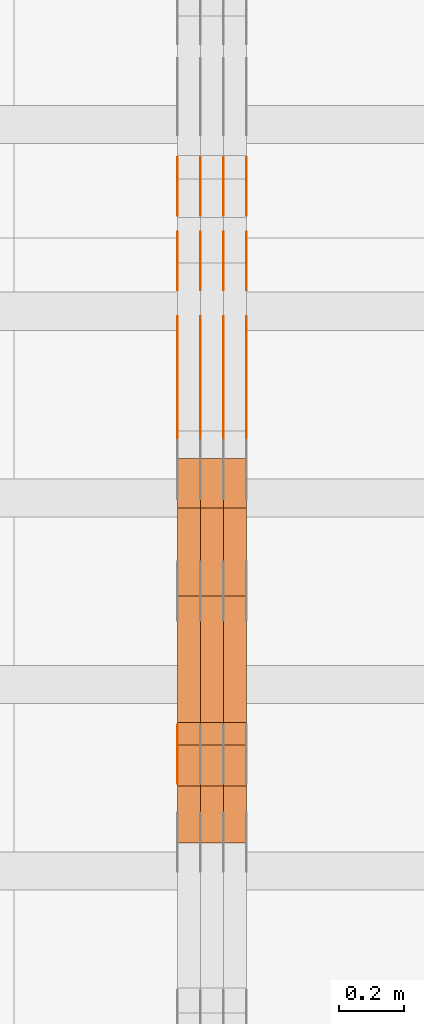
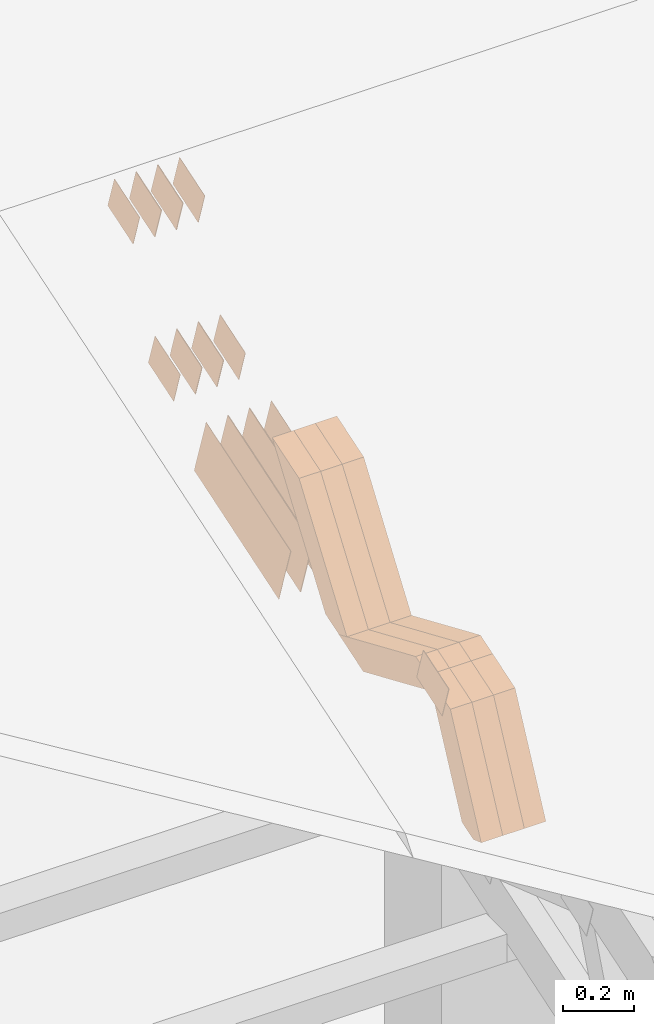
# One storey, part 115 of 385: 28 proxies.
"""IFC2X3 building model written with IfcOpenShell, lengths in millimetres."""

import ifcopenshell
import ifcopenshell.guid

model = None  # the IFC model being written
_history = None  # IfcOwnerHistory: only IFC2X3 demands one
_inside = {}  # id of a spatial element -> (the spatial element, [elements in it])
_under = {}  # id of a project, library or spatial element -> (it, [spatial elements below it])
_declared = {}  # id of a project -> (the project, [libraries it declares])
_typed = {}  # id of a type object -> (the type object, [elements of that type])
_made_of = {}  # id of a material, layer set ... -> (it, [elements and type objects made of it])


def new_model(schema):
    """Start an empty IFC model of exactly this schema.

    Asked for "IFC4X3", IfcOpenShell would pick the latest addendum, in which some entities
    have other attributes; the version numbers below select the first issue.
    IFC2X3 requires an IfcOwnerHistory on every rooted entity: one is made here for all.
    """
    global model, _history
    if schema == "IFC4X3":
        model = ifcopenshell.file(schema_version=(4, 3, 0, 0))
    else:
        model = ifcopenshell.file(schema=schema)
    _inside.clear()
    _under.clear()
    _declared.clear()
    _typed.clear()
    _made_of.clear()
    _history = None
    if model.schema == "IFC2X3":
        org = make("IfcOrganization", Name="unknown")
        user = make(
            "IfcPersonAndOrganization",
            ThePerson=make("IfcPerson", FamilyName="unknown"),
            TheOrganization=org,
        )
        app = make(
            "IfcApplication",
            ApplicationDeveloper=org,
            Version="unknown",
            ApplicationFullName="unknown",
            ApplicationIdentifier="unknown",
        )
        _history = make(
            "IfcOwnerHistory",
            OwningUser=user,
            OwningApplication=app,
            ChangeAction="ADDED",
            CreationDate=0,
        )
    return model


def make(cls, **values):
    """One entity of the class cls with the attributes given. An attribute that is None is left unset."""
    return model.create_entity(
        cls, **{name: value for name, value in values.items() if value is not None}
    )


def entity(cls, *values):
    """Any entity or typed value of the class cls, its attributes in the order of the schema. None: left unset."""
    e = model.create_entity(cls)
    for i, value in enumerate(values):
        if value is not None:
            e[i] = value
    return e


def rooted(cls, **values):
    """An entity with a GlobalId (a new one), such as an element, a storey or a relation."""
    return make(cls, GlobalId=ifcopenshell.guid.new(), OwnerHistory=_history, **values)


def si_unit(unit_type, name, prefix=None):
    """IfcSIUnit, for example si_unit("LENGTHUNIT", "METRE", prefix="MILLI")."""
    return make("IfcSIUnit", UnitType=unit_type, Prefix=prefix, Name=name)


def converted_unit(unit_type, name, factor, base, dimensions=None, offset=None):
    """IfcConversionBasedUnit, such as the inch: factor (a typed value) times the base unit."""
    return make(
        "IfcConversionBasedUnit"
        if offset is None
        else "IfcConversionBasedUnitWithOffset",
        ConversionOffset=offset,
        Dimensions=None
        if dimensions is None
        else entity("IfcDimensionalExponents", *dimensions),
        UnitType=unit_type,
        Name=name,
        ConversionFactor=make(
            "IfcMeasureWithUnit", ValueComponent=factor, UnitComponent=base
        ),
    )


def derived_unit(unit_type, elements):
    """IfcDerivedUnit: a product of units, each with its exponent."""
    return make(
        "IfcDerivedUnit",
        Elements=[
            make("IfcDerivedUnitElement", Unit=unit, Exponent=power)
            for unit, power in elements
        ],
        UnitType=unit_type,
    )


def assignment(units):
    """IfcUnitAssignment: the units of a project."""
    return None if units is None else make("IfcUnitAssignment", Units=units)


def point(xyz):
    """IfcCartesianPoint."""
    return None if xyz is None else make("IfcCartesianPoint", Coordinates=xyz)


def direction(xyz):
    """IfcDirection."""
    return None if xyz is None else make("IfcDirection", DirectionRatios=xyz)


def frame(location, z_axis=None, x_axis=None):
    """IfcAxis2Placement3D, a coordinate frame: its origin and axes. An axis left out is left unset."""
    return make(
        "IfcAxis2Placement3D",
        Location=point(location),
        Axis=direction(z_axis),
        RefDirection=direction(x_axis),
    )


def origin():
    """The frame at (0, 0, 0) with its axes left unset."""
    return frame((0.0, 0.0, 0.0))


def place(relative_to, where):
    """IfcLocalPlacement: puts the frame where relative to a parent placement (None: the world)."""
    return make(
        "IfcLocalPlacement", PlacementRelTo=relative_to, RelativePlacement=where
    )


def context(
    kind, dimensions, precision=None, world=None, true_north=None, identifier=None
):
    """IfcGeometricRepresentationContext, for example the 3D "Model" context."""
    return make(
        "IfcGeometricRepresentationContext",
        ContextIdentifier=identifier,
        ContextType=kind,
        CoordinateSpaceDimension=dimensions,
        Precision=precision,
        WorldCoordinateSystem=world,
        TrueNorth=true_north,
    )


def subcontext(parent, identifier, kind, view, scale=None):
    """IfcGeometricRepresentationSubContext, for example "Body" below "Model"."""
    return make(
        "IfcGeometricRepresentationSubContext",
        ContextIdentifier=identifier,
        ContextType=kind,
        ParentContext=parent,
        TargetScale=scale,
        TargetView=view,
    )


def project(units=None, contexts=None):
    """IfcProject with its units and contexts."""
    return rooted(
        "IfcProject",
        Name="project",
        RepresentationContexts=contexts,
        UnitsInContext=assignment(units),
    )


def spatial(cls, under=None, at=None, **own):
    """A site, building, storey or space (cls), placed at a placement, below another one or the project."""
    s = rooted(cls, ObjectPlacement=at, **own)
    if under is not None:
        _under.setdefault(under.id(), (under, []))[1].append(s)
    return s


def polyline(points):
    """IfcPolyline through the points."""
    return make("IfcPolyline", Points=[point(p) for p in points])


def outline(outer, holes=None, kind="AREA"):
    """IfcArbitraryClosedProfileDef: a profile drawn as a closed curve; with holes, ...WithVoids."""
    if holes is None:
        return make("IfcArbitraryClosedProfileDef", ProfileType=kind, OuterCurve=outer)
    return make(
        "IfcArbitraryProfileDefWithVoids",
        ProfileType=kind,
        OuterCurve=outer,
        InnerCurves=holes,
    )


def extrude(swept, where, along, depth):
    """IfcExtrudedAreaSolid: the profile swept, set in the frame where, extruded along a direction by depth."""
    return make(
        "IfcExtrudedAreaSolid",
        SweptArea=swept,
        Position=where,
        ExtrudedDirection=direction(along),
        Depth=depth,
    )


def shape(context_of_items, identifier, shape_type, items):
    """IfcShapeRepresentation: the items that make up one representation, for example the "Body"."""
    return make(
        "IfcShapeRepresentation",
        ContextOfItems=context_of_items,
        RepresentationIdentifier=identifier,
        RepresentationType=shape_type,
        Items=items,
    )


def source(mapping_origin, context_of_items, identifier, shape_type, items):
    """IfcRepresentationMap: a shape defined once, which mapped items show again and again."""
    return make(
        "IfcRepresentationMap",
        MappingOrigin=mapping_origin,
        MappedRepresentation=shape(context_of_items, identifier, shape_type, items),
    )


def transform(
    local_origin,
    x_axis=None,
    y_axis=None,
    z_axis=None,
    scale=None,
    scale2=None,
    scale3=None,
    uniform=True,
):
    """IfcCartesianTransformationOperator3D, or its non-uniform kind. x_axis, y_axis, z_axis: its Axis1, 2, 3."""
    if uniform:
        return make(
            "IfcCartesianTransformationOperator3D",
            Axis1=direction(x_axis),
            Axis2=direction(y_axis),
            LocalOrigin=point(local_origin),
            Scale=scale,
            Axis3=direction(z_axis),
        )
    return make(
        "IfcCartesianTransformationOperator3DnonUniform",
        Axis1=direction(x_axis),
        Axis2=direction(y_axis),
        LocalOrigin=point(local_origin),
        Scale=scale,
        Axis3=direction(z_axis),
        Scale2=scale2,
        Scale3=scale3,
    )


def mapped(mapping_source, mapping_target):
    """IfcMappedItem: shows the shape of a source again, moved by a transform."""
    return make(
        "IfcMappedItem", MappingSource=mapping_source, MappingTarget=mapping_target
    )


def material(Name=None, Category=None):
    """IfcMaterial."""
    return make("IfcMaterial", Name=Name, Category=Category)


def made_of(thing, what):
    """Note that an element or type object is made of a material, layer set ...; save() writes the relation."""
    if what is not None:
        _made_of.setdefault(what.id(), (what, []))[1].append(thing)
    return thing


def type_object(cls, material=None, **own):
    """A type object (cls), such as IfcWallType, which elements share."""
    return made_of(rooted(cls, **own), material)


def type_shapes(of_type, sources):
    """Give a type object the sources (RepresentationMaps) that its elements show as mapped items."""
    of_type.RepresentationMaps = sources


def element(
    cls,
    number,
    at=None,
    inside=None,
    cuts=None,
    type_object=None,
    material=None,
    context=None,
    identifier="Body",
    shape_type=None,
    held_by="IfcProductDefinitionShape",
    body=None,
    shapes=None,
    **own,
):
    """One element of the class cls, such as IfcWall. Its Tag is "e" and its number.

    at: its placement. inside: the storey or other place that contains it. cuts: it is an
    opening in that element (IfcRelVoidsElement). A single representation is given by context,
    identifier, shape_type and body (its items); several are given by shapes. held_by: the class
    of the entity that holds the representations. save() writes the other relations.
    """
    e = rooted(cls, Tag="e%d" % number, ObjectPlacement=at, **own)
    if body is not None:
        shapes = [shape(context, identifier, shape_type, body)]
    if shapes is not None:
        e.Representation = make(held_by, Representations=shapes)
    if inside is not None:
        _inside.setdefault(inside.id(), (inside, []))[1].append(e)
    if cuts is not None:
        rooted(
            "IfcRelVoidsElement", RelatingBuildingElement=cuts, RelatedOpeningElement=e
        )
    if type_object is not None:
        _typed.setdefault(type_object.id(), (type_object, []))[1].append(e)
    return made_of(e, material)


def aggregate(whole, parts):
    """IfcRelAggregates: a whole, such as a stair, and the parts it consists of."""
    return rooted("IfcRelAggregates", RelatingObject=whole, RelatedObjects=parts)


def save(model, path):
    """Write the relations noted so far, then the file.

    IfcRelAggregates (storeys below a building ...), IfcRelContainedInSpatialStructure (elements
    in a storey), IfcRelDefinesByType, IfcRelAssociatesMaterial and IfcRelDeclares: one each for
    every whole, place, type object, material and project.
    """
    for whole, parts in _under.values():
        aggregate(whole, parts)
    for where, things in _inside.values():
        rooted(
            "IfcRelContainedInSpatialStructure",
            RelatedElements=things,
            RelatingStructure=where,
        )
    for kind, things in _typed.values():
        rooted("IfcRelDefinesByType", RelatedObjects=things, RelatingType=kind)
    for what, things in _made_of.values():
        rooted("IfcRelAssociatesMaterial", RelatedObjects=things, RelatingMaterial=what)
    for by, libraries in _declared.values():
        rooted("IfcRelDeclares", RelatingContext=by, RelatedDefinitions=libraries)
    model.write(path)


model = new_model("IFC2X3")

# Units and contexts
model_context = context("Model", 3, precision=0.01, world=origin(), true_north=direction((6.12303176911189e-17, 1.0)))
body_context = subcontext(model_context, "Body", "Model", "MODEL_VIEW")
ifc_project = project(units=[si_unit("LENGTHUNIT", "METRE", prefix="MILLI"), si_unit("AREAUNIT", "SQUARE_METRE"), si_unit("VOLUMEUNIT", "CUBIC_METRE"), converted_unit("PLANEANGLEUNIT", "DEGREE", entity("IfcRatioMeasure", 0.0174532925199433), si_unit("PLANEANGLEUNIT", "RADIAN"), dimensions=[0, 0, 0, 0, 0, 0, 0]), si_unit("MASSUNIT", "GRAM", prefix="KILO"), derived_unit("MASSDENSITYUNIT", [(si_unit("MASSUNIT", "GRAM", prefix="KILO"), 1), (si_unit("LENGTHUNIT", "METRE"), -3)]), si_unit("TIMEUNIT", "SECOND"), si_unit("FREQUENCYUNIT", "HERTZ"), si_unit("THERMODYNAMICTEMPERATUREUNIT", "DEGREE_CELSIUS"), derived_unit("THERMALTRANSMITTANCEUNIT", [(si_unit("MASSUNIT", "GRAM", prefix="KILO"), 1), (si_unit("THERMODYNAMICTEMPERATUREUNIT", "KELVIN"), -1), (si_unit("TIMEUNIT", "SECOND"), -3)]), derived_unit("VOLUMETRICFLOWRATEUNIT", [(si_unit("LENGTHUNIT", "METRE"), 3), (si_unit("TIMEUNIT", "SECOND"), -1)]), si_unit("ELECTRICCURRENTUNIT", "AMPERE"), si_unit("ELECTRICVOLTAGEUNIT", "VOLT"), si_unit("POWERUNIT", "WATT"), si_unit("FORCEUNIT", "NEWTON", prefix="KILO"), si_unit("ILLUMINANCEUNIT", "LUX"), si_unit("LUMINOUSFLUXUNIT", "LUMEN"), si_unit("LUMINOUSINTENSITYUNIT", "CANDELA"), derived_unit("USERDEFINED", [(si_unit("MASSUNIT", "GRAM", prefix="KILO"), -1), (si_unit("LENGTHUNIT", "METRE"), -2), (si_unit("TIMEUNIT", "SECOND"), 3), (si_unit("LUMINOUSFLUXUNIT", "LUMEN"), 1)]), derived_unit("LINEARVELOCITYUNIT", [(si_unit("LENGTHUNIT", "METRE"), 1), (si_unit("TIMEUNIT", "SECOND"), -1)]), si_unit("PRESSUREUNIT", "PASCAL"), derived_unit("USERDEFINED", [(si_unit("LENGTHUNIT", "METRE"), -2), (si_unit("MASSUNIT", "GRAM", prefix="KILO"), 1), (si_unit("TIMEUNIT", "SECOND"), -2)])], contexts=[model_context])

# Site, building, storey
site_placement = place(None, origin())
site = spatial("IfcSite", under=ifc_project, at=site_placement, CompositionType="ELEMENT")
building_placement = place(site_placement, origin())
building = spatial("IfcBuilding", under=site, at=building_placement, CompositionType="ELEMENT")
storey_placement = place(building_placement, origin())
storey = spatial("IfcBuildingStorey", under=building, at=storey_placement, Name="Default", CompositionType="ELEMENT", Elevation=0.0)

# Proxies
ifc_material_1 = material(Name="IfcSurfaceStyle #247334")
building_element_proxy_type_1 = type_object("IfcBuildingElementProxyType", PredefinedType="NOTDEFINED", material=ifc_material_1)
shared_shape_1 = source(origin(), body_context, "Body", "SweptSolid", [
    extrude(outline(polyline([(-74.9998565677179, -60.000059685226), (74.9998794200128, -60.000059685226), (74.9998565677179, 60.000059685226), (-74.9998794200128, 60.000059685226), (-74.9998565677179, -60.000059685226)])), frame((75.0001976720505, 60.000059685226, 0.0), z_axis=(0.0, 0.0, 1.0), x_axis=(-1.0, 0.0, 0.0)), (0.0, 0.0, 1.0), 1.3),
])
type_shapes(building_element_proxy_type_1, [shared_shape_1])
proxy_1_placement = place(building_placement, frame((18386.3, 8537.53090236182, 1950.11166041942), z_axis=(-1.0, 0.0, 0.0), x_axis=(0.0, 0.951056516295124, 0.309016994375039)))
element("IfcBuildingElementProxy", 1, at=proxy_1_placement, inside=storey, type_object=building_element_proxy_type_1, material=ifc_material_1, context=body_context, shape_type="MappedRepresentation", body=[
    mapped(shared_shape_1, transform((0.0, 0.0, 0.0), scale=1.0)),
])
ifc_material_2 = material(Name="IfcSurfaceStyle #247277")
building_element_proxy_type_2 = type_object("IfcBuildingElementProxyType", PredefinedType="NOTDEFINED", material=ifc_material_2)
shared_shape_2 = source(origin(), body_context, "Body", "SweptSolid", [
    extrude(outline(polyline([(-74.9998565677179, -60.000059685226), (74.9998794200128, -60.000059685226), (74.9998565677179, 60.000059685226), (-74.9998794200128, 60.000059685226), (-74.9998565677179, -60.000059685226)])), frame((75.0001976720505, 60.000059685226, 0.0), z_axis=(0.0, 0.0, 1.0), x_axis=(-1.0, 0.0, 0.0)), (0.0, 0.0, 1.0), 1.3),
])
type_shapes(building_element_proxy_type_2, [shared_shape_2])
proxy_2_placement = place(building_placement, frame((18315.0, 8537.53090236182, 1950.11166041942), z_axis=(-1.0, 0.0, 0.0), x_axis=(0.0, 0.951056516295124, 0.309016994375039)))
element("IfcBuildingElementProxy", 2, at=proxy_2_placement, inside=storey, type_object=building_element_proxy_type_2, material=ifc_material_2, context=body_context, shape_type="MappedRepresentation", body=[
    mapped(shared_shape_2, transform((0.0, 0.0, 0.0), scale=1.0)),
])
ifc_material_3 = material(Name="IfcSurfaceStyle #247220")
building_element_proxy_type_3 = type_object("IfcBuildingElementProxyType", PredefinedType="NOTDEFINED", material=ifc_material_3)
shared_shape_3 = source(origin(), body_context, "Body", "SweptSolid", [
    extrude(outline(polyline([(-74.9998565677179, -60.000059685226), (74.9998794200128, -60.000059685226), (74.9998565677179, 60.000059685226), (-74.9998794200128, 60.000059685226), (-74.9998565677179, -60.000059685226)])), frame((75.0001976720505, 60.000059685226, 0.0), z_axis=(0.0, 0.0, 1.0), x_axis=(-1.0, 0.0, 0.0)), (0.0, 0.0, 1.0), 1.3),
])
type_shapes(building_element_proxy_type_3, [shared_shape_3])
proxy_3_placement = place(building_placement, frame((18316.3, 8537.53090236182, 1950.11166041942), z_axis=(-1.0, 0.0, 0.0), x_axis=(0.0, 0.951056516295124, 0.309016994375039)))
element("IfcBuildingElementProxy", 3, at=proxy_3_placement, inside=storey, type_object=building_element_proxy_type_3, material=ifc_material_3, context=body_context, shape_type="MappedRepresentation", body=[
    mapped(shared_shape_3, transform((0.0, 0.0, 0.0), scale=1.0)),
])
ifc_material_4 = material(Name="IfcSurfaceStyle #247163")
building_element_proxy_type_4 = type_object("IfcBuildingElementProxyType", PredefinedType="NOTDEFINED", material=ifc_material_4)
shared_shape_4 = source(origin(), body_context, "Body", "SweptSolid", [
    extrude(outline(polyline([(-74.9998565677179, -60.000059685226), (74.9998794200128, -60.000059685226), (74.9998565677179, 60.000059685226), (-74.9998794200128, 60.000059685226), (-74.9998565677179, -60.000059685226)])), frame((75.0001976720505, 60.000059685226, 0.0), z_axis=(0.0, 0.0, 1.0), x_axis=(-1.0, 0.0, 0.0)), (0.0, 0.0, 1.0), 1.29999999999999),
])
type_shapes(building_element_proxy_type_4, [shared_shape_4])
proxy_4_placement = place(building_placement, frame((18245.0, 8537.53090236182, 1950.11166041942), z_axis=(-1.0, 0.0, 0.0), x_axis=(0.0, 0.951056516295124, 0.309016994375039)))
element("IfcBuildingElementProxy", 4, at=proxy_4_placement, inside=storey, type_object=building_element_proxy_type_4, material=ifc_material_4, context=body_context, shape_type="MappedRepresentation", body=[
    mapped(shared_shape_4, transform((0.0, 0.0, 0.0), scale=1.0)),
])
ifc_material_5 = material(Name="IfcSurfaceStyle #247106")
building_element_proxy_type_5 = type_object("IfcBuildingElementProxyType", PredefinedType="NOTDEFINED", material=ifc_material_5)
shared_shape_5 = source(origin(), body_context, "Body", "SweptSolid", [
    extrude(outline(polyline([(-74.9998565677179, -60.000059685226), (74.9998794200128, -60.000059685226), (74.9998565677179, 60.000059685226), (-74.9998794200128, 60.000059685226), (-74.9998565677179, -60.000059685226)])), frame((75.0001976720505, 60.000059685226, 0.0), z_axis=(0.0, 0.0, 1.0), x_axis=(-1.0, 0.0, 0.0)), (0.0, 0.0, 1.0), 1.29999999999999),
])
type_shapes(building_element_proxy_type_5, [shared_shape_5])
proxy_5_placement = place(building_placement, frame((18246.3, 8537.53090236182, 1950.11166041942), z_axis=(-1.0, 0.0, 0.0), x_axis=(0.0, 0.951056516295124, 0.309016994375039)))
element("IfcBuildingElementProxy", 5, at=proxy_5_placement, inside=storey, type_object=building_element_proxy_type_5, material=ifc_material_5, context=body_context, shape_type="MappedRepresentation", body=[
    mapped(shared_shape_5, transform((0.0, 0.0, 0.0), scale=1.0)),
])
ifc_material_6 = material(Name="IfcSurfaceStyle #247049")
building_element_proxy_type_6 = type_object("IfcBuildingElementProxyType", PredefinedType="NOTDEFINED", material=ifc_material_6)
shared_shape_6 = source(origin(), body_context, "Body", "SweptSolid", [
    extrude(outline(polyline([(-74.9998565677179, -60.000059685226), (74.9998794200128, -60.000059685226), (74.9998565677179, 60.000059685226), (-74.9998794200128, 60.000059685226), (-74.9998565677179, -60.000059685226)])), frame((75.0001976720505, 60.000059685226, 0.0), z_axis=(0.0, 0.0, 1.0), x_axis=(-1.0, 0.0, 0.0)), (0.0, 0.0, 1.0), 1.29999999999999),
])
type_shapes(building_element_proxy_type_6, [shared_shape_6])
proxy_6_placement = place(building_placement, frame((18175.0, 8537.53090236182, 1950.11166041942), z_axis=(-1.0, 0.0, 0.0), x_axis=(0.0, 0.951056516295124, 0.309016994375039)))
element("IfcBuildingElementProxy", 6, at=proxy_6_placement, inside=storey, type_object=building_element_proxy_type_6, material=ifc_material_6, context=body_context, shape_type="MappedRepresentation", body=[
    mapped(shared_shape_6, transform((0.0, 0.0, 0.0), scale=1.0)),
])
ifc_material_7 = material(Name="IfcSurfaceStyle #246992")
building_element_proxy_type_7 = type_object("IfcBuildingElementProxyType", PredefinedType="NOTDEFINED", material=ifc_material_7)
shared_shape_7 = source(origin(), body_context, "Body", "SweptSolid", [
    extrude(outline(polyline([(-74.9998754286225, -60.0000016373515), (74.9998605591045, -60.0000016373515), (74.9998754286225, 60.0000016373515), (-74.9998605591045, 60.0000016373515), (-74.9998754286225, -60.0000016373515)])), frame((74.9998754286225, 60.0000016373515, 0.0), z_axis=(0.0, 0.0, 1.0), x_axis=(-1.0, 0.0, 0.0)), (0.0, 0.0, 1.0), 1.3),
])
type_shapes(building_element_proxy_type_7, [shared_shape_7])
proxy_7_placement = place(building_placement, frame((18386.3, 8765.47458614632, 2350.86432930304), z_axis=(-1.0, 0.0, 0.0), x_axis=(0.0, 0.951056516295154, 0.309016994374948)))
element("IfcBuildingElementProxy", 7, at=proxy_7_placement, inside=storey, type_object=building_element_proxy_type_7, material=ifc_material_7, context=body_context, shape_type="MappedRepresentation", body=[
    mapped(shared_shape_7, transform((0.0, 0.0, 0.0), scale=1.0)),
])
ifc_material_8 = material(Name="IfcSurfaceStyle #246935")
building_element_proxy_type_8 = type_object("IfcBuildingElementProxyType", PredefinedType="NOTDEFINED", material=ifc_material_8)
shared_shape_8 = source(origin(), body_context, "Body", "SweptSolid", [
    extrude(outline(polyline([(-74.9998754286225, -60.0000016373515), (74.9998605591045, -60.0000016373515), (74.9998754286225, 60.0000016373515), (-74.9998605591045, 60.0000016373515), (-74.9998754286225, -60.0000016373515)])), frame((74.9998754286225, 60.0000016373515, 0.0), z_axis=(0.0, 0.0, 1.0), x_axis=(-1.0, 0.0, 0.0)), (0.0, 0.0, 1.0), 1.3),
])
type_shapes(building_element_proxy_type_8, [shared_shape_8])
proxy_8_placement = place(building_placement, frame((18315.0, 8765.47458614632, 2350.86432930304), z_axis=(-1.0, 0.0, 0.0), x_axis=(0.0, 0.951056516295154, 0.309016994374948)))
element("IfcBuildingElementProxy", 8, at=proxy_8_placement, inside=storey, type_object=building_element_proxy_type_8, material=ifc_material_8, context=body_context, shape_type="MappedRepresentation", body=[
    mapped(shared_shape_8, transform((0.0, 0.0, 0.0), scale=1.0)),
])
ifc_material_9 = material(Name="IfcSurfaceStyle #246878")
building_element_proxy_type_9 = type_object("IfcBuildingElementProxyType", PredefinedType="NOTDEFINED", material=ifc_material_9)
shared_shape_9 = source(origin(), body_context, "Body", "SweptSolid", [
    extrude(outline(polyline([(-74.9998754286225, -60.0000016373515), (74.9998605591045, -60.0000016373515), (74.9998754286225, 60.0000016373515), (-74.9998605591045, 60.0000016373515), (-74.9998754286225, -60.0000016373515)])), frame((74.9998754286225, 60.0000016373515, 0.0), z_axis=(0.0, 0.0, 1.0), x_axis=(-1.0, 0.0, 0.0)), (0.0, 0.0, 1.0), 1.3),
])
type_shapes(building_element_proxy_type_9, [shared_shape_9])
proxy_9_placement = place(building_placement, frame((18316.3, 8765.47458614632, 2350.86432930304), z_axis=(-1.0, 0.0, 0.0), x_axis=(0.0, 0.951056516295154, 0.309016994374948)))
element("IfcBuildingElementProxy", 9, at=proxy_9_placement, inside=storey, type_object=building_element_proxy_type_9, material=ifc_material_9, context=body_context, shape_type="MappedRepresentation", body=[
    mapped(shared_shape_9, transform((0.0, 0.0, 0.0), scale=1.0)),
])
ifc_material_10 = material(Name="IfcSurfaceStyle #246821")
building_element_proxy_type_10 = type_object("IfcBuildingElementProxyType", PredefinedType="NOTDEFINED", material=ifc_material_10)
shared_shape_10 = source(origin(), body_context, "Body", "SweptSolid", [
    extrude(outline(polyline([(-74.9998754286225, -60.0000016373515), (74.9998605591045, -60.0000016373515), (74.9998754286225, 60.0000016373515), (-74.9998605591045, 60.0000016373515), (-74.9998754286225, -60.0000016373515)])), frame((74.9998754286225, 60.0000016373515, 0.0), z_axis=(0.0, 0.0, 1.0), x_axis=(-1.0, 0.0, 0.0)), (0.0, 0.0, 1.0), 1.29999999999999),
])
type_shapes(building_element_proxy_type_10, [shared_shape_10])
proxy_10_placement = place(building_placement, frame((18245.0, 8765.47458614632, 2350.86432930304), z_axis=(-1.0, 0.0, 0.0), x_axis=(0.0, 0.951056516295154, 0.309016994374948)))
element("IfcBuildingElementProxy", 10, at=proxy_10_placement, inside=storey, type_object=building_element_proxy_type_10, material=ifc_material_10, context=body_context, shape_type="MappedRepresentation", body=[
    mapped(shared_shape_10, transform((0.0, 0.0, 0.0), scale=1.0)),
])
ifc_material_11 = material(Name="IfcSurfaceStyle #246764")
building_element_proxy_type_11 = type_object("IfcBuildingElementProxyType", PredefinedType="NOTDEFINED", material=ifc_material_11)
shared_shape_11 = source(origin(), body_context, "Body", "SweptSolid", [
    extrude(outline(polyline([(-74.9998754286225, -60.0000016373515), (74.9998605591045, -60.0000016373515), (74.9998754286225, 60.0000016373515), (-74.9998605591045, 60.0000016373515), (-74.9998754286225, -60.0000016373515)])), frame((74.9998754286225, 60.0000016373515, 0.0), z_axis=(0.0, 0.0, 1.0), x_axis=(-1.0, 0.0, 0.0)), (0.0, 0.0, 1.0), 1.29999999999999),
])
type_shapes(building_element_proxy_type_11, [shared_shape_11])
proxy_11_placement = place(building_placement, frame((18246.3, 8765.47458614632, 2350.86432930304), z_axis=(-1.0, 0.0, 0.0), x_axis=(0.0, 0.951056516295154, 0.309016994374948)))
element("IfcBuildingElementProxy", 11, at=proxy_11_placement, inside=storey, type_object=building_element_proxy_type_11, material=ifc_material_11, context=body_context, shape_type="MappedRepresentation", body=[
    mapped(shared_shape_11, transform((0.0, 0.0, 0.0), scale=1.0)),
])
ifc_material_12 = material(Name="IfcSurfaceStyle #246707")
building_element_proxy_type_12 = type_object("IfcBuildingElementProxyType", PredefinedType="NOTDEFINED", material=ifc_material_12)
shared_shape_12 = source(origin(), body_context, "Body", "SweptSolid", [
    extrude(outline(polyline([(-74.9998754286225, -60.0000016373515), (74.9998605591045, -60.0000016373515), (74.9998754286225, 60.0000016373515), (-74.9998605591045, 60.0000016373515), (-74.9998754286225, -60.0000016373515)])), frame((74.9998754286225, 60.0000016373515, 0.0), z_axis=(0.0, 0.0, 1.0), x_axis=(-1.0, 0.0, 0.0)), (0.0, 0.0, 1.0), 1.29999999999999),
])
type_shapes(building_element_proxy_type_12, [shared_shape_12])
proxy_12_placement = place(building_placement, frame((18175.0, 8765.47458614632, 2350.86432930304), z_axis=(-1.0, 0.0, 0.0), x_axis=(0.0, 0.951056516295154, 0.309016994374948)))
element("IfcBuildingElementProxy", 12, at=proxy_12_placement, inside=storey, type_object=building_element_proxy_type_12, material=ifc_material_12, context=body_context, shape_type="MappedRepresentation", body=[
    mapped(shared_shape_12, transform((0.0, 0.0, 0.0), scale=1.0)),
])
ifc_material_13 = material(Name="IfcSurfaceStyle #246308")
building_element_proxy_type_13 = type_object("IfcBuildingElementProxyType", PredefinedType="NOTDEFINED", material=ifc_material_13)
shared_shape_13 = source(origin(), body_context, "Body", "SweptSolid", [
    extrude(outline(polyline([(-249.999749056184, -108.000229288163), (249.999396050782, -108.000229288163), (249.999749056184, 108.000229288163), (-249.999396050782, 108.000229288163), (-249.999749056184, -108.000229288163)])), frame((249.999841104007, 108.000229288163, 0.0), z_axis=(0.0, 0.0, 1.0), x_axis=(-1.0, 0.0, 0.0)), (0.0, 0.0, 1.0), 1.29999999999998),
])
type_shapes(building_element_proxy_type_13, [shared_shape_13])
proxy_13_placement = place(building_placement, frame((18386.3, 7917.13457673635, 1720.66532252899), z_axis=(-1.0, 0.0, 0.0), x_axis=(0.0, 0.951056516295124, 0.309016994375039)))
element("IfcBuildingElementProxy", 13, at=proxy_13_placement, inside=storey, type_object=building_element_proxy_type_13, material=ifc_material_13, context=body_context, shape_type="MappedRepresentation", body=[
    mapped(shared_shape_13, transform((0.0, 0.0, 0.0), scale=1.0)),
])
ifc_material_14 = material(Name="IfcSurfaceStyle #246251")
building_element_proxy_type_14 = type_object("IfcBuildingElementProxyType", PredefinedType="NOTDEFINED", material=ifc_material_14)
shared_shape_14 = source(origin(), body_context, "Body", "SweptSolid", [
    extrude(outline(polyline([(-249.999749056184, -108.000229288163), (249.999396050782, -108.000229288163), (249.999749056184, 108.000229288163), (-249.999396050782, 108.000229288163), (-249.999749056184, -108.000229288163)])), frame((249.999841104007, 108.000229288163, 0.0), z_axis=(0.0, 0.0, 1.0), x_axis=(-1.0, 0.0, 0.0)), (0.0, 0.0, 1.0), 1.29999999999998),
])
type_shapes(building_element_proxy_type_14, [shared_shape_14])
proxy_14_placement = place(building_placement, frame((18315.0, 7917.13457673635, 1720.66532252899), z_axis=(-1.0, 0.0, 0.0), x_axis=(0.0, 0.951056516295124, 0.309016994375039)))
element("IfcBuildingElementProxy", 14, at=proxy_14_placement, inside=storey, type_object=building_element_proxy_type_14, material=ifc_material_14, context=body_context, shape_type="MappedRepresentation", body=[
    mapped(shared_shape_14, transform((0.0, 0.0, 0.0), scale=1.0)),
])
ifc_material_15 = material(Name="IfcSurfaceStyle #246194")
building_element_proxy_type_15 = type_object("IfcBuildingElementProxyType", PredefinedType="NOTDEFINED", material=ifc_material_15)
shared_shape_15 = source(origin(), body_context, "Body", "SweptSolid", [
    extrude(outline(polyline([(-249.999749056184, -108.000229288163), (249.999396050782, -108.000229288163), (249.999749056184, 108.000229288163), (-249.999396050782, 108.000229288163), (-249.999749056184, -108.000229288163)])), frame((249.999841104007, 108.000229288163, 0.0), z_axis=(0.0, 0.0, 1.0), x_axis=(-1.0, 0.0, 0.0)), (0.0, 0.0, 1.0), 1.29999999999998),
])
type_shapes(building_element_proxy_type_15, [shared_shape_15])
proxy_15_placement = place(building_placement, frame((18316.3, 7917.13457673635, 1720.66532252899), z_axis=(-1.0, 0.0, 0.0), x_axis=(0.0, 0.951056516295124, 0.309016994375039)))
element("IfcBuildingElementProxy", 15, at=proxy_15_placement, inside=storey, type_object=building_element_proxy_type_15, material=ifc_material_15, context=body_context, shape_type="MappedRepresentation", body=[
    mapped(shared_shape_15, transform((0.0, 0.0, 0.0), scale=1.0)),
])
ifc_material_16 = material(Name="IfcSurfaceStyle #246137")
building_element_proxy_type_16 = type_object("IfcBuildingElementProxyType", PredefinedType="NOTDEFINED", material=ifc_material_16)
shared_shape_16 = source(origin(), body_context, "Body", "SweptSolid", [
    extrude(outline(polyline([(-249.999749056184, -108.000229288163), (249.999396050782, -108.000229288163), (249.999749056184, 108.000229288163), (-249.999396050782, 108.000229288163), (-249.999749056184, -108.000229288163)])), frame((249.999841104007, 108.000229288163, 0.0), z_axis=(0.0, 0.0, 1.0), x_axis=(-1.0, 0.0, 0.0)), (0.0, 0.0, 1.0), 1.29999999999997),
])
type_shapes(building_element_proxy_type_16, [shared_shape_16])
proxy_16_placement = place(building_placement, frame((18245.0, 7917.13457673635, 1720.66532252899), z_axis=(-1.0, 0.0, 0.0), x_axis=(0.0, 0.951056516295124, 0.309016994375039)))
element("IfcBuildingElementProxy", 16, at=proxy_16_placement, inside=storey, type_object=building_element_proxy_type_16, material=ifc_material_16, context=body_context, shape_type="MappedRepresentation", body=[
    mapped(shared_shape_16, transform((0.0, 0.0, 0.0), scale=1.0)),
])
ifc_material_17 = material(Name="IfcSurfaceStyle #246080")
building_element_proxy_type_17 = type_object("IfcBuildingElementProxyType", PredefinedType="NOTDEFINED", material=ifc_material_17)
shared_shape_17 = source(origin(), body_context, "Body", "SweptSolid", [
    extrude(outline(polyline([(-249.999749056184, -108.000229288163), (249.999396050782, -108.000229288163), (249.999749056184, 108.000229288163), (-249.999396050782, 108.000229288163), (-249.999749056184, -108.000229288163)])), frame((249.999841104007, 108.000229288163, 0.0), z_axis=(0.0, 0.0, 1.0), x_axis=(-1.0, 0.0, 0.0)), (0.0, 0.0, 1.0), 1.29999999999997),
])
type_shapes(building_element_proxy_type_17, [shared_shape_17])
proxy_17_placement = place(building_placement, frame((18246.3, 7917.13457673635, 1720.66532252899), z_axis=(-1.0, 0.0, 0.0), x_axis=(0.0, 0.951056516295124, 0.309016994375039)))
element("IfcBuildingElementProxy", 17, at=proxy_17_placement, inside=storey, type_object=building_element_proxy_type_17, material=ifc_material_17, context=body_context, shape_type="MappedRepresentation", body=[
    mapped(shared_shape_17, transform((0.0, 0.0, 0.0), scale=1.0)),
])
ifc_material_18 = material(Name="IfcSurfaceStyle #246023")
building_element_proxy_type_18 = type_object("IfcBuildingElementProxyType", PredefinedType="NOTDEFINED", material=ifc_material_18)
shared_shape_18 = source(origin(), body_context, "Body", "SweptSolid", [
    extrude(outline(polyline([(-249.999749056184, -108.000229288163), (249.999396050782, -108.000229288163), (249.999749056184, 108.000229288163), (-249.999396050782, 108.000229288163), (-249.999749056184, -108.000229288163)])), frame((249.999841104007, 108.000229288163, 0.0), z_axis=(0.0, 0.0, 1.0), x_axis=(-1.0, 0.0, 0.0)), (0.0, 0.0, 1.0), 1.29999999999997),
])
type_shapes(building_element_proxy_type_18, [shared_shape_18])
proxy_18_placement = place(building_placement, frame((18175.0, 7917.13457673635, 1720.66532252899), z_axis=(-1.0, 0.0, 0.0), x_axis=(0.0, 0.951056516295124, 0.309016994375039)))
element("IfcBuildingElementProxy", 18, at=proxy_18_placement, inside=storey, type_object=building_element_proxy_type_18, material=ifc_material_18, context=body_context, shape_type="MappedRepresentation", body=[
    mapped(shared_shape_18, transform((0.0, 0.0, 0.0), scale=1.0)),
])
ifc_material_19 = material(Name="IfcSurfaceStyle #231659")
building_element_proxy_type_19 = type_object("IfcBuildingElementProxyType", PredefinedType="NOTDEFINED", material=ifc_material_19)
shared_shape_19 = source(origin(), body_context, "Body", "SweptSolid", [
    extrude(outline(polyline([(-74.9998565677233, -60.0000596852342), (74.9998794200074, -60.0000596852342), (74.9998565677233, 60.0000596852342), (-74.9998794200074, 60.0000596852342), (-74.9998565677233, -60.0000596852342)])), frame((74.9998794200073, 60.0000596852342, 0.0), z_axis=(0.0, 0.0, 1.0), x_axis=(-1.0, 0.0, 0.0)), (0.0, 0.0, 1.0), 1.29999999999999),
])
type_shapes(building_element_proxy_type_19, [shared_shape_19])
proxy_19_placement = place(building_placement, frame((18175.0, 7029.15620503751, 1786.70025974129), z_axis=(-1.0, 0.0, 0.0), x_axis=(0.0, 0.951056516295154, 0.309016994374948)))
element("IfcBuildingElementProxy", 19, at=proxy_19_placement, inside=storey, type_object=building_element_proxy_type_19, material=ifc_material_19, context=body_context, shape_type="MappedRepresentation", body=[
    mapped(shared_shape_19, transform((0.0, 0.0, 0.0), scale=1.0)),
])
ifc_material_20 = material(Name="IfcSurfaceStyle #219452")
building_element_proxy_type_20 = type_object("IfcBuildingElementProxyType", Name="T1-W17 219450", PredefinedType="NOTDEFINED", material=ifc_material_20)
shared_shape_20 = source(origin(), body_context, "Body", "SweptSolid", [
    extrude(outline(polyline([(-364.271754334175, -47.5002955168173), (154.762247185537, -47.5002955168173), (218.32500198375, 4.1746158945366e-05), (228.330650189718, 47.5002746437378), (-237.14614502483, 47.5002746437378), (-364.271754334175, -47.5002955168173)])), frame((228.330650189718, 47.5002746437378, 0.0), z_axis=(0.0, 0.0, 1.0), x_axis=(-1.0, 0.0, 0.0)), (0.0, 0.0, 1.0), 70.0),
])
type_shapes(building_element_proxy_type_20, [shared_shape_20])
proxy_20_placement = place(building_placement, frame((18385.0, 7603.591796875, 1617.27880859375), z_axis=(-1.0, 0.0, 0.0), x_axis=(0.0, 0.576852646364743, 0.816848226038346)))
element("IfcBuildingElementProxy", 20, at=proxy_20_placement, inside=storey, type_object=building_element_proxy_type_20, material=ifc_material_20, Name="T1-W17", context=body_context, shape_type="MappedRepresentation", body=[
    mapped(shared_shape_20, transform((0.0, 0.0, 0.0), scale=1.0)),
])
ifc_material_21 = material(Name="IfcSurfaceStyle #219386")
building_element_proxy_type_21 = type_object("IfcBuildingElementProxyType", Name="T1-W17 219384", PredefinedType="NOTDEFINED", material=ifc_material_21)
shared_shape_21 = source(origin(), body_context, "Body", "SweptSolid", [
    extrude(outline(polyline([(-364.271754334175, -47.5002955168173), (154.762247185537, -47.5002955168173), (218.32500198375, 4.1746158945366e-05), (228.330650189718, 47.5002746437378), (-237.14614502483, 47.5002746437378), (-364.271754334175, -47.5002955168173)])), frame((228.330650189718, 47.5002746437378, 0.0), z_axis=(0.0, 0.0, 1.0), x_axis=(-1.0, 0.0, 0.0)), (0.0, 0.0, 1.0), 70.0),
])
type_shapes(building_element_proxy_type_21, [shared_shape_21])
proxy_21_placement = place(building_placement, frame((18315.0, 7603.591796875, 1617.27880859375), z_axis=(-1.0, 0.0, 0.0), x_axis=(0.0, 0.576852646364743, 0.816848226038346)))
element("IfcBuildingElementProxy", 21, at=proxy_21_placement, inside=storey, type_object=building_element_proxy_type_21, material=ifc_material_21, Name="T1-W17", context=body_context, shape_type="MappedRepresentation", body=[
    mapped(shared_shape_21, transform((0.0, 0.0, 0.0), scale=1.0)),
])
ifc_material_22 = material(Name="IfcSurfaceStyle #219320")
building_element_proxy_type_22 = type_object("IfcBuildingElementProxyType", Name="T1-W17 219318", PredefinedType="NOTDEFINED", material=ifc_material_22)
shared_shape_22 = source(origin(), body_context, "Body", "SweptSolid", [
    extrude(outline(polyline([(-364.271754334175, -47.5002955168173), (154.762247185537, -47.5002955168173), (218.32500198375, 4.1746158945366e-05), (228.330650189718, 47.5002746437378), (-237.14614502483, 47.5002746437378), (-364.271754334175, -47.5002955168173)])), frame((228.330650189718, 47.5002746437378, 0.0), z_axis=(0.0, 0.0, 1.0), x_axis=(-1.0, 0.0, 0.0)), (0.0, 0.0, 1.0), 70.0),
])
type_shapes(building_element_proxy_type_22, [shared_shape_22])
proxy_22_placement = place(building_placement, frame((18245.0, 7603.591796875, 1617.27880859375), z_axis=(-1.0, 0.0, 0.0), x_axis=(0.0, 0.576852646364743, 0.816848226038346)))
element("IfcBuildingElementProxy", 22, at=proxy_22_placement, inside=storey, type_object=building_element_proxy_type_22, material=ifc_material_22, Name="T1-W17", context=body_context, shape_type="MappedRepresentation", body=[
    mapped(shared_shape_22, transform((0.0, 0.0, 0.0), scale=1.0)),
])
ifc_material_23 = material(Name="IfcSurfaceStyle #219056")
building_element_proxy_type_23 = type_object("IfcBuildingElementProxyType", Name="T1-W28 219054", PredefinedType="NOTDEFINED", material=ifc_material_23)
shared_shape_23 = source(origin(), body_context, "Body", "SweptSolid", [
    extrude(outline(polyline([(-217.926999432742, -47.5002417204892), (200.85556309928, -47.5002417204892), (198.503183549447, 8.27993157516647e-05), (144.500539771884, 47.5002003208314), (-325.932286987868, 47.5002003208314), (-217.926999432742, -47.5002417204892)])), frame((200.855855188284, 47.5002003208314, 0.0), z_axis=(0.0, 0.0, 1.0), x_axis=(-1.0, 0.0, 0.0)), (0.0, 0.0, 1.0), 70.0),
])
type_shapes(building_element_proxy_type_23, [shared_shape_23])
proxy_23_placement = place(building_placement, frame((18385.0, 7164.46308589723, 1806.71154838415), z_axis=(-1.0, 0.0, 0.0), x_axis=(0.0, 0.918207947119617, -0.396098681954861)))
element("IfcBuildingElementProxy", 23, at=proxy_23_placement, inside=storey, type_object=building_element_proxy_type_23, material=ifc_material_23, Name="T1-W28", context=body_context, shape_type="MappedRepresentation", body=[
    mapped(shared_shape_23, transform((0.0, 0.0, 0.0), scale=1.0)),
])
ifc_material_24 = material(Name="IfcSurfaceStyle #218990")
building_element_proxy_type_24 = type_object("IfcBuildingElementProxyType", Name="T1-W28 218988", PredefinedType="NOTDEFINED", material=ifc_material_24)
shared_shape_24 = source(origin(), body_context, "Body", "SweptSolid", [
    extrude(outline(polyline([(-217.926999432742, -47.5002417204892), (200.85556309928, -47.5002417204892), (198.503183549447, 8.27993157516647e-05), (144.500539771884, 47.5002003208314), (-325.932286987868, 47.5002003208314), (-217.926999432742, -47.5002417204892)])), frame((200.855855188284, 47.5002003208314, 0.0), z_axis=(0.0, 0.0, 1.0), x_axis=(-1.0, 0.0, 0.0)), (0.0, 0.0, 1.0), 70.0),
])
type_shapes(building_element_proxy_type_24, [shared_shape_24])
proxy_24_placement = place(building_placement, frame((18315.0, 7164.46308589723, 1806.71154838415), z_axis=(-1.0, 0.0, 0.0), x_axis=(0.0, 0.918207947119617, -0.396098681954861)))
element("IfcBuildingElementProxy", 24, at=proxy_24_placement, inside=storey, type_object=building_element_proxy_type_24, material=ifc_material_24, Name="T1-W28", context=body_context, shape_type="MappedRepresentation", body=[
    mapped(shared_shape_24, transform((0.0, 0.0, 0.0), scale=1.0)),
])
ifc_material_25 = material(Name="IfcSurfaceStyle #218924")
building_element_proxy_type_25 = type_object("IfcBuildingElementProxyType", Name="T1-W28 218922", PredefinedType="NOTDEFINED", material=ifc_material_25)
shared_shape_25 = source(origin(), body_context, "Body", "SweptSolid", [
    extrude(outline(polyline([(-217.926999432742, -47.5002417204892), (200.85556309928, -47.5002417204892), (198.503183549447, 8.27993157516647e-05), (144.500539771884, 47.5002003208314), (-325.932286987868, 47.5002003208314), (-217.926999432742, -47.5002417204892)])), frame((200.855855188284, 47.5002003208314, 0.0), z_axis=(0.0, 0.0, 1.0), x_axis=(-1.0, 0.0, 0.0)), (0.0, 0.0, 1.0), 70.0),
])
type_shapes(building_element_proxy_type_25, [shared_shape_25])
proxy_25_placement = place(building_placement, frame((18245.0, 7164.46308589723, 1806.71154838415), z_axis=(-1.0, 0.0, 0.0), x_axis=(0.0, 0.918207947119617, -0.396098681954861)))
element("IfcBuildingElementProxy", 25, at=proxy_25_placement, inside=storey, type_object=building_element_proxy_type_25, material=ifc_material_25, Name="T1-W28", context=body_context, shape_type="MappedRepresentation", body=[
    mapped(shared_shape_25, transform((0.0, 0.0, 0.0), scale=1.0)),
])
ifc_material_26 = material(Name="IfcSurfaceStyle #218660")
building_element_proxy_type_26 = type_object("IfcBuildingElementProxyType", Name="T1-W38 218658", PredefinedType="NOTDEFINED", material=ifc_material_26)
shared_shape_26 = source(origin(), body_context, "Body", "SweptSolid", [
    extrude(outline(polyline([(-298.027186733919, -47.5000251939178), (135.138415004037, -47.5000251939178), (181.282052802132, 0.000918984287993996), (187.347601017465, 47.4995657017738), (-205.740882089715, 47.4995657017739), (-298.027186733919, -47.5000251939178)])), frame((187.347846776827, 47.5001085012031, 0.0), z_axis=(0.0, 0.0, 1.0), x_axis=(-1.0, 0.0, 0.0)), (0.0, 0.0, 1.0), 70.0),
])
type_shapes(building_element_proxy_type_26, [shared_shape_26])
proxy_26_placement = place(building_placement, frame((18385.0, 6848.47987320449, 1368.44362234215), z_axis=(-1.0, 0.0, 0.0), x_axis=(0.0, 0.441034274474743, 0.897490261082836)))
element("IfcBuildingElementProxy", 26, at=proxy_26_placement, inside=storey, type_object=building_element_proxy_type_26, material=ifc_material_26, Name="T1-W38", context=body_context, shape_type="MappedRepresentation", body=[
    mapped(shared_shape_26, transform((0.0, 0.0, 0.0), scale=1.0)),
])
ifc_material_27 = material(Name="IfcSurfaceStyle #218594")
building_element_proxy_type_27 = type_object("IfcBuildingElementProxyType", Name="T1-W38 218592", PredefinedType="NOTDEFINED", material=ifc_material_27)
shared_shape_27 = source(origin(), body_context, "Body", "SweptSolid", [
    extrude(outline(polyline([(-298.027186733919, -47.5000251939178), (135.138415004037, -47.5000251939178), (181.282052802132, 0.000918984287993996), (187.347601017465, 47.4995657017738), (-205.740882089715, 47.4995657017739), (-298.027186733919, -47.5000251939178)])), frame((187.347846776827, 47.5001085012031, 0.0), z_axis=(0.0, 0.0, 1.0), x_axis=(-1.0, 0.0, 0.0)), (0.0, 0.0, 1.0), 70.0),
])
type_shapes(building_element_proxy_type_27, [shared_shape_27])
proxy_27_placement = place(building_placement, frame((18315.0, 6848.47987320449, 1368.44362234215), z_axis=(-1.0, 0.0, 0.0), x_axis=(0.0, 0.441034274474743, 0.897490261082836)))
element("IfcBuildingElementProxy", 27, at=proxy_27_placement, inside=storey, type_object=building_element_proxy_type_27, material=ifc_material_27, Name="T1-W38", context=body_context, shape_type="MappedRepresentation", body=[
    mapped(shared_shape_27, transform((0.0, 0.0, 0.0), scale=1.0)),
])
ifc_material_28 = material(Name="IfcSurfaceStyle #218528")
building_element_proxy_type_28 = type_object("IfcBuildingElementProxyType", Name="T1-W38 218526", PredefinedType="NOTDEFINED", material=ifc_material_28)
shared_shape_28 = source(origin(), body_context, "Body", "SweptSolid", [
    extrude(outline(polyline([(-298.027186733919, -47.5000251939178), (135.138415004037, -47.5000251939178), (181.282052802132, 0.000918984287993996), (187.347601017465, 47.4995657017738), (-205.740882089715, 47.4995657017739), (-298.027186733919, -47.5000251939178)])), frame((187.347846776827, 47.5001085012031, 0.0), z_axis=(0.0, 0.0, 1.0), x_axis=(-1.0, 0.0, 0.0)), (0.0, 0.0, 1.0), 70.0),
])
type_shapes(building_element_proxy_type_28, [shared_shape_28])
proxy_28_placement = place(building_placement, frame((18245.0, 6848.47987320449, 1368.44362234215), z_axis=(-1.0, 0.0, 0.0), x_axis=(0.0, 0.441034274474743, 0.897490261082836)))
element("IfcBuildingElementProxy", 28, at=proxy_28_placement, inside=storey, type_object=building_element_proxy_type_28, material=ifc_material_28, Name="T1-W38", context=body_context, shape_type="MappedRepresentation", body=[
    mapped(shared_shape_28, transform((0.0, 0.0, 0.0), scale=1.0)),
])

save(model, "model.ifc")
